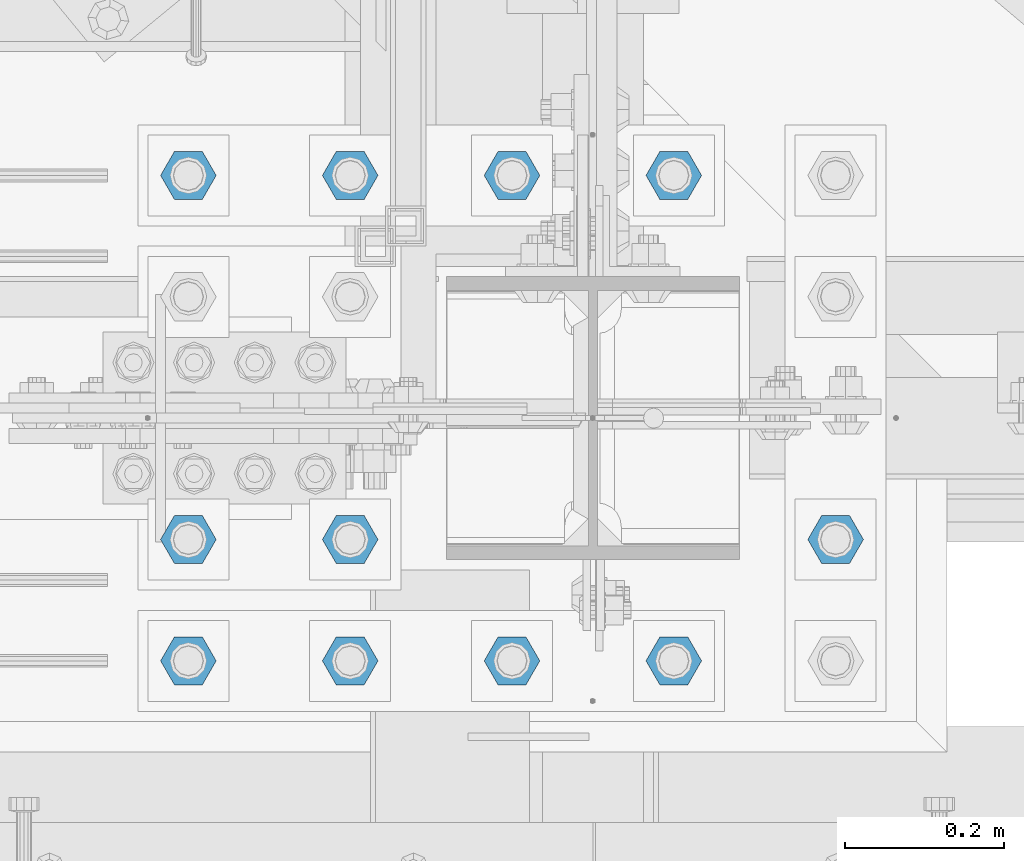
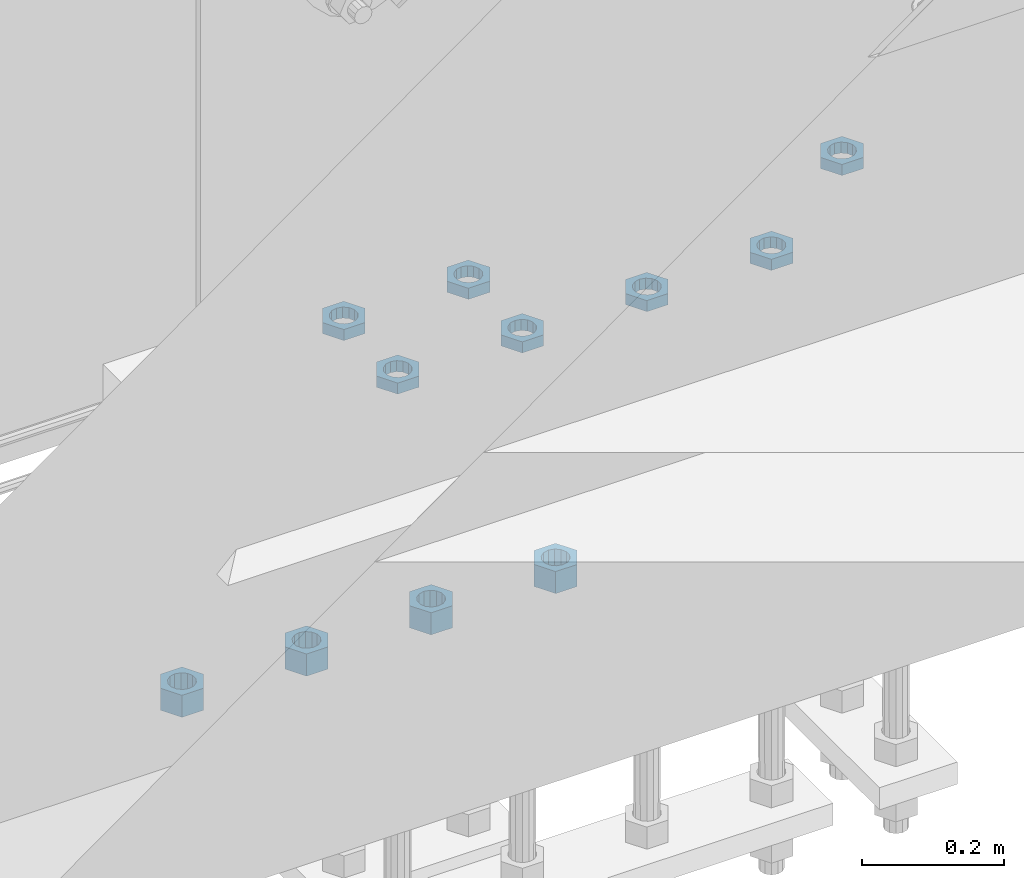
# One storey, part 2816 of 3843: 11 beams, 1 element without a shape of its own.
"""IFC2X3 building model written with IfcOpenShell, lengths in millimetres."""

from ifc_helpers import new_model, si_unit, frame, origin_with_axes, place, context, subcontext, project, spatial, faceted_brep, material, type_object, element, aggregate, save


model = new_model("IFC2X3")

# Units and contexts
model_context = context("Model", 3, precision=1e-05, world=origin_with_axes())
body_context = subcontext(model_context, "Body", "Model", "MODEL_VIEW")
ifc_project = project(units=[si_unit("LENGTHUNIT", "METRE", prefix="MILLI"), si_unit("AREAUNIT", "SQUARE_METRE"), si_unit("VOLUMEUNIT", "CUBIC_METRE"), si_unit("MASSUNIT", "GRAM", prefix="KILO"), si_unit("TIMEUNIT", "SECOND"), si_unit("PLANEANGLEUNIT", "RADIAN"), si_unit("SOLIDANGLEUNIT", "STERADIAN"), si_unit("THERMODYNAMICTEMPERATUREUNIT", "DEGREE_CELSIUS"), si_unit("LUMINOUSINTENSITYUNIT", "LUMEN")], contexts=[model_context])

# Site, building, storey
site_placement = place(None, origin_with_axes())
site = spatial("IfcSite", under=ifc_project, at=site_placement, CompositionType="ELEMENT")
building_placement = place(site_placement, origin_with_axes())
building = spatial("IfcBuilding", under=site, at=building_placement, Name="Undefined", CompositionType="ELEMENT")
storey_placement = place(building_placement, origin_with_axes())
storey = spatial("IfcBuildingStorey", under=building, at=storey_placement, Name="Undefined", CompositionType="ELEMENT", Elevation=0.0)

# Assembly, beams
assembly_placement = place(storey_placement, origin_with_axes())
assembly = element("IfcElementAssembly", 1, at=assembly_placement, inside=storey, Name="TEMPLATE", AssemblyPlace="NOTDEFINED", PredefinedType="RIGID_FRAME")
ifc_material = material(Name="STEEL/A572-50")
beam_type_1 = type_object("IfcBeamType", Name="1-1/2_HEAVY_HEX_NUT", PredefinedType="NOTDEFINED")
beam_1_placement = place(assembly_placement, frame((49098.2, 25920.7, 28841.7000015259), z_axis=(0.0, -1.0, 0.0), x_axis=(0.0, 0.0, -1.0)))
beam_1 = element("IfcBeam", 2, at=beam_1_placement, type_object=beam_type_1, material=ifc_material, Name="NUT", ObjectType="1-1/2_HEAVY_HEX_NUT", context=body_context, shape_type="Brep", body=[
    faceted_brep([(0.0, -34.9199981689453, 0.0), (0.0, -17.4599990844727, -30.25), (38.0999999999985, -17.4599990844727, -30.25), (38.0999999999985, -34.9199981689453, 0.0), (0.0, 17.4599990844727, -30.25), (38.0999999999985, 17.4599990844727, -30.25), (0.0, 34.9199981689453, 0.0), (38.0999999999985, 34.9199981689453, 0.0), (0.0, 17.4599990844727, 30.25), (38.0999999999985, 17.4599990844727, 30.25), (0.0, -17.4599990844727, 30.25), (38.0999999999985, -17.4599990844727, 30.25), (0.0, 0.0, 20.6399993896484), (0.0, 8.9553601105581, 18.5959968835959), (38.0999999999985, 8.9553601105581, 18.5959968835959), (38.0999999999985, 0.0, 20.6399993896484), (0.0, 16.1370013209525, 12.8688291298167), (38.0999999999985, 16.1370013209525, 12.8688291298167), (0.0, 20.1225115123816, 4.59283194104501), (38.0999999999985, 20.1225115123816, 4.59283194104501), (0.0, 20.1225115123816, -4.59283194104501), (38.0999999999985, 20.1225115123816, -4.59283194104501), (0.0, 16.1370013209525, -12.8688291298167), (38.0999999999985, 16.1370013209525, -12.8688291298167), (0.0, 8.9553601105581, -18.5959968835959), (38.0999999999985, 8.9553601105581, -18.5959968835959), (0.0, 0.0, -20.6399993896484), (38.0999999999985, 0.0, -20.6399993896484), (0.0, -8.9553601105581, -18.5959968835959), (38.0999999999985, -8.9553601105581, -18.5959968835959), (0.0, -16.1370013209525, -12.8688291298167), (38.0999999999985, -16.1370013209525, -12.8688291298167), (0.0, -20.1225115123816, -4.59283194104501), (38.0999999999985, -20.1225115123816, -4.59283194104501), (0.0, -20.1225115123816, 4.59283194104501), (38.0999999999985, -20.1225115123816, 4.59283194104501), (0.0, -16.1370013209525, 12.8688291298167), (38.0999999999985, -16.1370013209525, 12.8688291298167), (0.0, -8.9553601105581, 18.5959968835959), (38.0999999999985, -8.9553601105581, 18.5959968835959)], [[[0, 1, 2, 3]], [[1, 4, 5, 2]], [[4, 6, 7, 5]], [[6, 8, 9, 7]], [[8, 10, 11, 9]], [[10, 0, 3, 11]], [[12, 13, 14, 15]], [[13, 16, 17, 14]], [[16, 18, 19, 17]], [[18, 20, 21, 19]], [[20, 22, 23, 21]], [[22, 24, 25, 23]], [[24, 26, 27, 25]], [[26, 28, 29, 27]], [[28, 30, 31, 29]], [[30, 32, 33, 31]], [[32, 34, 35, 33]], [[34, 36, 37, 35]], [[36, 38, 39, 37]], [[38, 12, 15, 39]], [[5, 7, 9, 11, 3, 2], [17, 19, 21, 23, 25, 27, 29, 31, 33, 35, 37, 39, 15, 14]], [[10, 8, 6, 4, 1, 0], [38, 36, 34, 32, 30, 28, 26, 24, 22, 20, 18, 16, 13, 12]]]),
])
beam_2_placement = place(assembly_placement, frame((48895.0, 25920.7, 28841.7000015259), z_axis=(0.0, -1.0, 0.0), x_axis=(0.0, 0.0, -1.0)))
beam_2 = element("IfcBeam", 3, at=beam_2_placement, type_object=beam_type_1, material=ifc_material, Name="NUT", ObjectType="1-1/2_HEAVY_HEX_NUT", context=body_context, shape_type="Brep", body=[
    faceted_brep([(0.0, -34.9199981689453, 0.0), (0.0, -17.4599990844727, -30.25), (38.0999999999985, -17.4599990844727, -30.25), (38.0999999999985, -34.9199981689453, 0.0), (0.0, 17.4599990844727, -30.25), (38.0999999999985, 17.4599990844727, -30.25), (0.0, 34.9199981689453, 0.0), (38.0999999999985, 34.9199981689453, 0.0), (0.0, 17.4599990844727, 30.25), (38.0999999999985, 17.4599990844727, 30.25), (0.0, -17.4599990844727, 30.25), (38.0999999999985, -17.4599990844727, 30.25), (0.0, 0.0, 20.6399993896484), (0.0, 8.9553601105581, 18.5959968835959), (38.0999999999985, 8.9553601105581, 18.5959968835959), (38.0999999999985, 0.0, 20.6399993896484), (0.0, 16.1370013209525, 12.8688291298167), (38.0999999999985, 16.1370013209525, 12.8688291298167), (0.0, 20.1225115123816, 4.59283194104501), (38.0999999999985, 20.1225115123816, 4.59283194104501), (0.0, 20.1225115123816, -4.59283194104501), (38.0999999999985, 20.1225115123816, -4.59283194104501), (0.0, 16.1370013209525, -12.8688291298167), (38.0999999999985, 16.1370013209525, -12.8688291298167), (0.0, 8.9553601105581, -18.5959968835959), (38.0999999999985, 8.9553601105581, -18.5959968835959), (0.0, 0.0, -20.6399993896484), (38.0999999999985, 0.0, -20.6399993896484), (0.0, -8.9553601105581, -18.5959968835959), (38.0999999999985, -8.9553601105581, -18.5959968835959), (0.0, -16.1370013209525, -12.8688291298167), (38.0999999999985, -16.1370013209525, -12.8688291298167), (0.0, -20.1225115123816, -4.59283194104501), (38.0999999999985, -20.1225115123816, -4.59283194104501), (0.0, -20.1225115123816, 4.59283194104501), (38.0999999999985, -20.1225115123816, 4.59283194104501), (0.0, -16.1370013209525, 12.8688291298167), (38.0999999999985, -16.1370013209525, 12.8688291298167), (0.0, -8.9553601105581, 18.5959968835959), (38.0999999999985, -8.9553601105581, 18.5959968835959)], [[[0, 1, 2, 3]], [[1, 4, 5, 2]], [[4, 6, 7, 5]], [[6, 8, 9, 7]], [[8, 10, 11, 9]], [[10, 0, 3, 11]], [[12, 13, 14, 15]], [[13, 16, 17, 14]], [[16, 18, 19, 17]], [[18, 20, 21, 19]], [[20, 22, 23, 21]], [[22, 24, 25, 23]], [[24, 26, 27, 25]], [[26, 28, 29, 27]], [[28, 30, 31, 29]], [[30, 32, 33, 31]], [[32, 34, 35, 33]], [[34, 36, 37, 35]], [[36, 38, 39, 37]], [[38, 12, 15, 39]], [[5, 7, 9, 11, 3, 2], [17, 19, 21, 23, 25, 27, 29, 31, 33, 35, 37, 39, 15, 14]], [[10, 8, 6, 4, 1, 0], [38, 36, 34, 32, 30, 28, 26, 24, 22, 20, 18, 16, 13, 12]]]),
])
beam_3_placement = place(assembly_placement, frame((48691.8, 25920.7, 28841.7000015259), z_axis=(0.0, 1.0, 0.0), x_axis=(0.0, 0.0, -1.0)))
beam_3 = element("IfcBeam", 4, at=beam_3_placement, type_object=beam_type_1, material=ifc_material, Name="NUT", ObjectType="1-1/2_HEAVY_HEX_NUT", context=body_context, shape_type="Brep", body=[
    faceted_brep([(0.0, -34.9199981689453, 0.0), (0.0, -17.4599990844727, -30.25), (38.0999999999985, -17.4599990844727, -30.25), (38.0999999999985, -34.9199981689453, 0.0), (0.0, 17.4599990844727, -30.25), (38.0999999999985, 17.4599990844727, -30.25), (0.0, 34.9199981689453, 0.0), (38.0999999999985, 34.9199981689453, 0.0), (0.0, 17.4599990844727, 30.25), (38.0999999999985, 17.4599990844727, 30.25), (0.0, -17.4599990844727, 30.25), (38.0999999999985, -17.4599990844727, 30.25), (0.0, 0.0, 20.6399993896484), (0.0, 8.9553601105581, 18.5959968835959), (38.0999999999985, 8.9553601105581, 18.5959968835959), (38.0999999999985, 0.0, 20.6399993896484), (0.0, 16.1370013209525, 12.8688291298167), (38.0999999999985, 16.1370013209525, 12.8688291298167), (0.0, 20.1225115123816, 4.59283194104501), (38.0999999999985, 20.1225115123816, 4.59283194104501), (0.0, 20.1225115123816, -4.59283194104501), (38.0999999999985, 20.1225115123816, -4.59283194104501), (0.0, 16.1370013209525, -12.8688291298167), (38.0999999999985, 16.1370013209525, -12.8688291298167), (0.0, 8.9553601105581, -18.5959968835959), (38.0999999999985, 8.9553601105581, -18.5959968835959), (0.0, 0.0, -20.6399993896484), (38.0999999999985, 0.0, -20.6399993896484), (0.0, -8.9553601105581, -18.5959968835959), (38.0999999999985, -8.9553601105581, -18.5959968835959), (0.0, -16.1370013209525, -12.8688291298167), (38.0999999999985, -16.1370013209525, -12.8688291298167), (0.0, -20.1225115123816, -4.59283194104501), (38.0999999999985, -20.1225115123816, -4.59283194104501), (0.0, -20.1225115123816, 4.59283194104501), (38.0999999999985, -20.1225115123816, 4.59283194104501), (0.0, -16.1370013209525, 12.8688291298167), (38.0999999999985, -16.1370013209525, 12.8688291298167), (0.0, -8.9553601105581, 18.5959968835959), (38.0999999999985, -8.9553601105581, 18.5959968835959)], [[[0, 1, 2, 3]], [[1, 4, 5, 2]], [[4, 6, 7, 5]], [[6, 8, 9, 7]], [[8, 10, 11, 9]], [[10, 0, 3, 11]], [[12, 13, 14, 15]], [[13, 16, 17, 14]], [[16, 18, 19, 17]], [[18, 20, 21, 19]], [[20, 22, 23, 21]], [[22, 24, 25, 23]], [[24, 26, 27, 25]], [[26, 28, 29, 27]], [[28, 30, 31, 29]], [[30, 32, 33, 31]], [[32, 34, 35, 33]], [[34, 36, 37, 35]], [[36, 38, 39, 37]], [[38, 12, 15, 39]], [[5, 7, 9, 11, 3, 2], [17, 19, 21, 23, 25, 27, 29, 31, 33, 35, 37, 39, 15, 14]], [[10, 8, 6, 4, 1, 0], [38, 36, 34, 32, 30, 28, 26, 24, 22, 20, 18, 16, 13, 12]]]),
])
beam_4_placement = place(assembly_placement, frame((48488.6, 25920.7, 28841.7000015259), z_axis=(0.0, 1.0, 0.0), x_axis=(0.0, 0.0, -1.0)))
beam_4 = element("IfcBeam", 5, at=beam_4_placement, type_object=beam_type_1, material=ifc_material, Name="NUT", ObjectType="1-1/2_HEAVY_HEX_NUT", context=body_context, shape_type="Brep", body=[
    faceted_brep([(0.0, -34.9199981689453, 0.0), (0.0, -17.4599990844727, -30.25), (38.0999999999985, -17.4599990844727, -30.25), (38.0999999999985, -34.9199981689453, 0.0), (0.0, 17.4599990844727, -30.25), (38.0999999999985, 17.4599990844727, -30.25), (0.0, 34.9199981689453, 0.0), (38.0999999999985, 34.9199981689453, 0.0), (0.0, 17.4599990844727, 30.25), (38.0999999999985, 17.4599990844727, 30.25), (0.0, -17.4599990844727, 30.25), (38.0999999999985, -17.4599990844727, 30.25), (0.0, 0.0, 20.6399993896484), (0.0, 8.9553601105581, 18.5959968835959), (38.0999999999985, 8.9553601105581, 18.5959968835959), (38.0999999999985, 0.0, 20.6399993896484), (0.0, 16.1370013209525, 12.8688291298167), (38.0999999999985, 16.1370013209525, 12.8688291298167), (0.0, 20.1225115123816, 4.59283194104501), (38.0999999999985, 20.1225115123816, 4.59283194104501), (0.0, 20.1225115123816, -4.59283194104501), (38.0999999999985, 20.1225115123816, -4.59283194104501), (0.0, 16.1370013209525, -12.8688291298167), (38.0999999999985, 16.1370013209525, -12.8688291298167), (0.0, 8.9553601105581, -18.5959968835959), (38.0999999999985, 8.9553601105581, -18.5959968835959), (0.0, 0.0, -20.6399993896484), (38.0999999999985, 0.0, -20.6399993896484), (0.0, -8.9553601105581, -18.5959968835959), (38.0999999999985, -8.9553601105581, -18.5959968835959), (0.0, -16.1370013209525, -12.8688291298167), (38.0999999999985, -16.1370013209525, -12.8688291298167), (0.0, -20.1225115123816, -4.59283194104501), (38.0999999999985, -20.1225115123816, -4.59283194104501), (0.0, -20.1225115123816, 4.59283194104501), (38.0999999999985, -20.1225115123816, 4.59283194104501), (0.0, -16.1370013209525, 12.8688291298167), (38.0999999999985, -16.1370013209525, 12.8688291298167), (0.0, -8.9553601105581, 18.5959968835959), (38.0999999999985, -8.9553601105581, 18.5959968835959)], [[[0, 1, 2, 3]], [[1, 4, 5, 2]], [[4, 6, 7, 5]], [[6, 8, 9, 7]], [[8, 10, 11, 9]], [[10, 0, 3, 11]], [[12, 13, 14, 15]], [[13, 16, 17, 14]], [[16, 18, 19, 17]], [[18, 20, 21, 19]], [[20, 22, 23, 21]], [[22, 24, 25, 23]], [[24, 26, 27, 25]], [[26, 28, 29, 27]], [[28, 30, 31, 29]], [[30, 32, 33, 31]], [[32, 34, 35, 33]], [[34, 36, 37, 35]], [[36, 38, 39, 37]], [[38, 12, 15, 39]], [[5, 7, 9, 11, 3, 2], [17, 19, 21, 23, 25, 27, 29, 31, 33, 35, 37, 39, 15, 14]], [[10, 8, 6, 4, 1, 0], [38, 36, 34, 32, 30, 28, 26, 24, 22, 20, 18, 16, 13, 12]]]),
])
beam_type_2 = type_object("IfcBeamType", Name="1-1/2_HALF_NUT", PredefinedType="NOTDEFINED")
beam_5_placement = place(assembly_placement, frame((49098.2, 25311.1, 29749.75), z_axis=(0.0, -1.0, 0.0), x_axis=(0.0, 0.0, -1.0)))
beam_5 = element("IfcBeam", 6, at=beam_5_placement, type_object=beam_type_2, material=ifc_material, Name="NUT", ObjectType="1-1/2_HALF_NUT", context=body_context, shape_type="Brep", body=[
    faceted_brep([(0.0, -34.9199981689453, 0.0), (0.0, -17.4599990844727, -30.25), (19.0500000000029, -17.4599990844727, -30.25), (19.0500000000029, -34.9199981689453, 0.0), (0.0, 17.4599990844727, -30.25), (19.0500000000029, 17.4599990844727, -30.25), (0.0, 34.9199981689453, 0.0), (19.0500000000029, 34.9199981689453, 0.0), (0.0, 17.4599990844727, 30.25), (19.0500000000029, 17.4599990844727, 30.25), (0.0, -17.4599990844727, 30.25), (19.0500000000029, -17.4599990844727, 30.25), (0.0, 0.0, 20.6399993896484), (0.0, 8.9553601105581, 18.5959968835959), (19.0500000000029, 8.95536011056538, 18.5959968835959), (19.0500000000029, 0.0, 20.6399993896484), (0.0, 16.1370013209525, 12.8688291298167), (19.0500000000029, 16.1370013209489, 12.8688291298167), (0.0, 20.1225115123816, 4.59283194104501), (19.0500000000029, 20.1225115123852, 4.59283194104501), (0.0, 20.1225115123816, -4.59283194104501), (19.0500000000029, 20.1225115123852, -4.59283194104501), (0.0, 16.1370013209525, -12.8688291298167), (19.0500000000029, 16.1370013209489, -12.8688291298167), (0.0, 8.9553601105581, -18.5959968835959), (19.0500000000029, 8.95536011056538, -18.5959968835959), (0.0, 0.0, -20.6399993896484), (19.0500000000029, 0.0, -20.6399993896484), (0.0, -8.9553601105581, -18.5959968835959), (19.0500000000029, -8.95536011056538, -18.5959968835959), (0.0, -16.1370013209525, -12.8688291298167), (19.0500000000029, -16.1370013209489, -12.8688291298167), (0.0, -20.1225115123816, -4.59283194104501), (19.0500000000029, -20.1225115123852, -4.59283194104501), (0.0, -20.1225115123816, 4.59283194104501), (19.0500000000029, -20.1225115123852, 4.59283194104501), (0.0, -16.1370013209525, 12.8688291298167), (19.0500000000029, -16.1370013209489, 12.8688291298167), (0.0, -8.9553601105581, 18.5959968835959), (19.0500000000029, -8.95536011056538, 18.5959968835959)], [[[0, 1, 2, 3]], [[1, 4, 5, 2]], [[4, 6, 7, 5]], [[6, 8, 9, 7]], [[8, 10, 11, 9]], [[10, 0, 3, 11]], [[12, 13, 14, 15]], [[13, 16, 17, 14]], [[16, 18, 19, 17]], [[18, 20, 21, 19]], [[20, 22, 23, 21]], [[22, 24, 25, 23]], [[24, 26, 27, 25]], [[26, 28, 29, 27]], [[28, 30, 31, 29]], [[30, 32, 33, 31]], [[32, 34, 35, 33]], [[34, 36, 37, 35]], [[36, 38, 39, 37]], [[38, 12, 15, 39]], [[5, 7, 9, 11, 3, 2], [17, 19, 21, 23, 25, 27, 29, 31, 33, 35, 37, 39, 15, 14]], [[10, 8, 6, 4, 1, 0], [38, 36, 34, 32, 30, 28, 26, 24, 22, 20, 18, 16, 13, 12]]]),
])
beam_6_placement = place(assembly_placement, frame((48895.0, 25311.1, 29749.75), z_axis=(0.0, -1.0, 0.0), x_axis=(0.0, 0.0, -1.0)))
beam_6 = element("IfcBeam", 7, at=beam_6_placement, type_object=beam_type_2, material=ifc_material, Name="NUT", ObjectType="1-1/2_HALF_NUT", context=body_context, shape_type="Brep", body=[
    faceted_brep([(0.0, -34.9199981689453, 0.0), (0.0, -17.4599990844727, -30.25), (19.0500000000029, -17.4599990844727, -30.25), (19.0500000000029, -34.9199981689453, 0.0), (0.0, 17.4599990844727, -30.25), (19.0500000000029, 17.4599990844727, -30.25), (0.0, 34.9199981689453, 0.0), (19.0500000000029, 34.9199981689453, 0.0), (0.0, 17.4599990844727, 30.25), (19.0500000000029, 17.4599990844727, 30.25), (0.0, -17.4599990844727, 30.25), (19.0500000000029, -17.4599990844727, 30.25), (0.0, 0.0, 20.6399993896484), (0.0, 8.9553601105581, 18.5959968835959), (19.0500000000029, 8.95536011056538, 18.5959968835959), (19.0500000000029, 0.0, 20.6399993896484), (0.0, 16.1370013209525, 12.8688291298167), (19.0500000000029, 16.1370013209489, 12.8688291298167), (0.0, 20.1225115123816, 4.59283194104501), (19.0500000000029, 20.1225115123852, 4.59283194104501), (0.0, 20.1225115123816, -4.59283194104501), (19.0500000000029, 20.1225115123852, -4.59283194104501), (0.0, 16.1370013209525, -12.8688291298167), (19.0500000000029, 16.1370013209489, -12.8688291298167), (0.0, 8.9553601105581, -18.5959968835959), (19.0500000000029, 8.95536011056538, -18.5959968835959), (0.0, 0.0, -20.6399993896484), (19.0500000000029, 0.0, -20.6399993896484), (0.0, -8.9553601105581, -18.5959968835959), (19.0500000000029, -8.95536011056538, -18.5959968835959), (0.0, -16.1370013209525, -12.8688291298167), (19.0500000000029, -16.1370013209489, -12.8688291298167), (0.0, -20.1225115123816, -4.59283194104501), (19.0500000000029, -20.1225115123852, -4.59283194104501), (0.0, -20.1225115123816, 4.59283194104501), (19.0500000000029, -20.1225115123852, 4.59283194104501), (0.0, -16.1370013209525, 12.8688291298167), (19.0500000000029, -16.1370013209489, 12.8688291298167), (0.0, -8.9553601105581, 18.5959968835959), (19.0500000000029, -8.95536011056538, 18.5959968835959)], [[[0, 1, 2, 3]], [[1, 4, 5, 2]], [[4, 6, 7, 5]], [[6, 8, 9, 7]], [[8, 10, 11, 9]], [[10, 0, 3, 11]], [[12, 13, 14, 15]], [[13, 16, 17, 14]], [[16, 18, 19, 17]], [[18, 20, 21, 19]], [[20, 22, 23, 21]], [[22, 24, 25, 23]], [[24, 26, 27, 25]], [[26, 28, 29, 27]], [[28, 30, 31, 29]], [[30, 32, 33, 31]], [[32, 34, 35, 33]], [[34, 36, 37, 35]], [[36, 38, 39, 37]], [[38, 12, 15, 39]], [[5, 7, 9, 11, 3, 2], [17, 19, 21, 23, 25, 27, 29, 31, 33, 35, 37, 39, 15, 14]], [[10, 8, 6, 4, 1, 0], [38, 36, 34, 32, 30, 28, 26, 24, 22, 20, 18, 16, 13, 12]]]),
])
beam_7_placement = place(assembly_placement, frame((48691.8, 25311.1, 29749.75), z_axis=(0.0, 1.0, 0.0), x_axis=(0.0, 0.0, -1.0)))
beam_7 = element("IfcBeam", 8, at=beam_7_placement, type_object=beam_type_2, material=ifc_material, Name="NUT", ObjectType="1-1/2_HALF_NUT", context=body_context, shape_type="Brep", body=[
    faceted_brep([(0.0, -34.9199981689453, 0.0), (0.0, -17.4599990844727, -30.25), (19.0500000000029, -17.4599990844727, -30.25), (19.0500000000029, -34.9199981689453, 0.0), (0.0, 17.4599990844727, -30.25), (19.0500000000029, 17.4599990844727, -30.25), (0.0, 34.9199981689453, 0.0), (19.0500000000029, 34.9199981689453, 0.0), (0.0, 17.4599990844727, 30.25), (19.0500000000029, 17.4599990844727, 30.25), (0.0, -17.4599990844727, 30.25), (19.0500000000029, -17.4599990844727, 30.25), (0.0, 0.0, 20.6399993896484), (0.0, 8.9553601105581, 18.5959968835959), (19.0500000000029, 8.95536011056538, 18.5959968835959), (19.0500000000029, 0.0, 20.6399993896484), (0.0, 16.1370013209525, 12.8688291298167), (19.0500000000029, 16.1370013209489, 12.8688291298167), (0.0, 20.1225115123816, 4.59283194104501), (19.0500000000029, 20.1225115123852, 4.59283194104501), (0.0, 20.1225115123816, -4.59283194104501), (19.0500000000029, 20.1225115123852, -4.59283194104501), (0.0, 16.1370013209525, -12.8688291298167), (19.0500000000029, 16.1370013209489, -12.8688291298167), (0.0, 8.9553601105581, -18.5959968835959), (19.0500000000029, 8.95536011056538, -18.5959968835959), (0.0, 0.0, -20.6399993896484), (19.0500000000029, 0.0, -20.6399993896484), (0.0, -8.9553601105581, -18.5959968835959), (19.0500000000029, -8.95536011056538, -18.5959968835959), (0.0, -16.1370013209525, -12.8688291298167), (19.0500000000029, -16.1370013209489, -12.8688291298167), (0.0, -20.1225115123816, -4.59283194104501), (19.0500000000029, -20.1225115123852, -4.59283194104501), (0.0, -20.1225115123816, 4.59283194104501), (19.0500000000029, -20.1225115123852, 4.59283194104501), (0.0, -16.1370013209525, 12.8688291298167), (19.0500000000029, -16.1370013209489, 12.8688291298167), (0.0, -8.9553601105581, 18.5959968835959), (19.0500000000029, -8.95536011056538, 18.5959968835959)], [[[0, 1, 2, 3]], [[1, 4, 5, 2]], [[4, 6, 7, 5]], [[6, 8, 9, 7]], [[8, 10, 11, 9]], [[10, 0, 3, 11]], [[12, 13, 14, 15]], [[13, 16, 17, 14]], [[16, 18, 19, 17]], [[18, 20, 21, 19]], [[20, 22, 23, 21]], [[22, 24, 25, 23]], [[24, 26, 27, 25]], [[26, 28, 29, 27]], [[28, 30, 31, 29]], [[30, 32, 33, 31]], [[32, 34, 35, 33]], [[34, 36, 37, 35]], [[36, 38, 39, 37]], [[38, 12, 15, 39]], [[5, 7, 9, 11, 3, 2], [17, 19, 21, 23, 25, 27, 29, 31, 33, 35, 37, 39, 15, 14]], [[10, 8, 6, 4, 1, 0], [38, 36, 34, 32, 30, 28, 26, 24, 22, 20, 18, 16, 13, 12]]]),
])
beam_8_placement = place(assembly_placement, frame((48488.6, 25311.1, 29749.75), z_axis=(0.0, 1.0, 0.0), x_axis=(0.0, 0.0, -1.0)))
beam_8 = element("IfcBeam", 9, at=beam_8_placement, type_object=beam_type_2, material=ifc_material, Name="NUT", ObjectType="1-1/2_HALF_NUT", context=body_context, shape_type="Brep", body=[
    faceted_brep([(0.0, -34.9199981689453, 0.0), (0.0, -17.4599990844727, -30.25), (19.0500000000029, -17.4599990844727, -30.25), (19.0500000000029, -34.9199981689453, 0.0), (0.0, 17.4599990844727, -30.25), (19.0500000000029, 17.4599990844727, -30.25), (0.0, 34.9199981689453, 0.0), (19.0500000000029, 34.9199981689453, 0.0), (0.0, 17.4599990844727, 30.25), (19.0500000000029, 17.4599990844727, 30.25), (0.0, -17.4599990844727, 30.25), (19.0500000000029, -17.4599990844727, 30.25), (0.0, 0.0, 20.6399993896484), (0.0, 8.9553601105581, 18.5959968835959), (19.0500000000029, 8.95536011056538, 18.5959968835959), (19.0500000000029, 0.0, 20.6399993896484), (0.0, 16.1370013209525, 12.8688291298167), (19.0500000000029, 16.1370013209489, 12.8688291298167), (0.0, 20.1225115123816, 4.59283194104501), (19.0500000000029, 20.1225115123852, 4.59283194104501), (0.0, 20.1225115123816, -4.59283194104501), (19.0500000000029, 20.1225115123852, -4.59283194104501), (0.0, 16.1370013209525, -12.8688291298167), (19.0500000000029, 16.1370013209489, -12.8688291298167), (0.0, 8.9553601105581, -18.5959968835959), (19.0500000000029, 8.95536011056538, -18.5959968835959), (0.0, 0.0, -20.6399993896484), (19.0500000000029, 0.0, -20.6399993896484), (0.0, -8.9553601105581, -18.5959968835959), (19.0500000000029, -8.95536011056538, -18.5959968835959), (0.0, -16.1370013209525, -12.8688291298167), (19.0500000000029, -16.1370013209489, -12.8688291298167), (0.0, -20.1225115123816, -4.59283194104501), (19.0500000000029, -20.1225115123852, -4.59283194104501), (0.0, -20.1225115123816, 4.59283194104501), (19.0500000000029, -20.1225115123852, 4.59283194104501), (0.0, -16.1370013209525, 12.8688291298167), (19.0500000000029, -16.1370013209489, 12.8688291298167), (0.0, -8.9553601105581, 18.5959968835959), (19.0500000000029, -8.95536011056538, 18.5959968835959)], [[[0, 1, 2, 3]], [[1, 4, 5, 2]], [[4, 6, 7, 5]], [[6, 8, 9, 7]], [[8, 10, 11, 9]], [[10, 0, 3, 11]], [[12, 13, 14, 15]], [[13, 16, 17, 14]], [[16, 18, 19, 17]], [[18, 20, 21, 19]], [[20, 22, 23, 21]], [[22, 24, 25, 23]], [[24, 26, 27, 25]], [[26, 28, 29, 27]], [[28, 30, 31, 29]], [[30, 32, 33, 31]], [[32, 34, 35, 33]], [[34, 36, 37, 35]], [[36, 38, 39, 37]], [[38, 12, 15, 39]], [[5, 7, 9, 11, 3, 2], [17, 19, 21, 23, 25, 27, 29, 31, 33, 35, 37, 39, 15, 14]], [[10, 8, 6, 4, 1, 0], [38, 36, 34, 32, 30, 28, 26, 24, 22, 20, 18, 16, 13, 12]]]),
])
beam_9_placement = place(assembly_placement, frame((49301.4, 25463.5, 29749.75), z_axis=(0.0, -1.0, 0.0), x_axis=(0.0, 0.0, -1.0)))
beam_9 = element("IfcBeam", 10, at=beam_9_placement, type_object=beam_type_2, material=ifc_material, Name="NUT", ObjectType="1-1/2_HALF_NUT", context=body_context, shape_type="Brep", body=[
    faceted_brep([(0.0, -34.9199981689453, 0.0), (0.0, -17.4599990844727, -30.25), (19.0500000000029, -17.4599990844727, -30.25), (19.0500000000029, -34.9199981689453, 0.0), (0.0, 17.4599990844727, -30.25), (19.0500000000029, 17.4599990844727, -30.25), (0.0, 34.9199981689453, 0.0), (19.0500000000029, 34.9199981689453, 0.0), (0.0, 17.4599990844727, 30.25), (19.0500000000029, 17.4599990844727, 30.25), (0.0, -17.4599990844727, 30.25), (19.0500000000029, -17.4599990844727, 30.25), (0.0, 0.0, 20.6399993896484), (0.0, 8.9553601105581, 18.5959968835959), (19.0500000000029, 8.95536011056538, 18.5959968835959), (19.0500000000029, 0.0, 20.6399993896484), (0.0, 16.1370013209525, 12.8688291298167), (19.0500000000029, 16.1370013209489, 12.8688291298167), (0.0, 20.1225115123816, 4.59283194104501), (19.0500000000029, 20.1225115123852, 4.59283194104501), (0.0, 20.1225115123816, -4.59283194104501), (19.0500000000029, 20.1225115123852, -4.59283194104501), (0.0, 16.1370013209525, -12.8688291298167), (19.0500000000029, 16.1370013209489, -12.8688291298167), (0.0, 8.9553601105581, -18.5959968835959), (19.0500000000029, 8.95536011056538, -18.5959968835959), (0.0, 0.0, -20.6399993896484), (19.0500000000029, 0.0, -20.6399993896484), (0.0, -8.9553601105581, -18.5959968835959), (19.0500000000029, -8.95536011056538, -18.5959968835959), (0.0, -16.1370013209525, -12.8688291298167), (19.0500000000029, -16.1370013209489, -12.8688291298167), (0.0, -20.1225115123816, -4.59283194104501), (19.0500000000029, -20.1225115123852, -4.59283194104501), (0.0, -20.1225115123816, 4.59283194104501), (19.0500000000029, -20.1225115123852, 4.59283194104501), (0.0, -16.1370013209525, 12.8688291298167), (19.0500000000029, -16.1370013209489, 12.8688291298167), (0.0, -8.9553601105581, 18.5959968835959), (19.0500000000029, -8.95536011056538, 18.5959968835959)], [[[0, 1, 2, 3]], [[1, 4, 5, 2]], [[4, 6, 7, 5]], [[6, 8, 9, 7]], [[8, 10, 11, 9]], [[10, 0, 3, 11]], [[12, 13, 14, 15]], [[13, 16, 17, 14]], [[16, 18, 19, 17]], [[18, 20, 21, 19]], [[20, 22, 23, 21]], [[22, 24, 25, 23]], [[24, 26, 27, 25]], [[26, 28, 29, 27]], [[28, 30, 31, 29]], [[30, 32, 33, 31]], [[32, 34, 35, 33]], [[34, 36, 37, 35]], [[36, 38, 39, 37]], [[38, 12, 15, 39]], [[5, 7, 9, 11, 3, 2], [17, 19, 21, 23, 25, 27, 29, 31, 33, 35, 37, 39, 15, 14]], [[10, 8, 6, 4, 1, 0], [38, 36, 34, 32, 30, 28, 26, 24, 22, 20, 18, 16, 13, 12]]]),
])
beam_10_placement = place(assembly_placement, frame((48691.8, 25463.5, 29749.75), z_axis=(0.0, 1.0, 0.0), x_axis=(0.0, 0.0, -1.0)))
beam_10 = element("IfcBeam", 11, at=beam_10_placement, type_object=beam_type_2, material=ifc_material, Name="NUT", ObjectType="1-1/2_HALF_NUT", context=body_context, shape_type="Brep", body=[
    faceted_brep([(0.0, -34.9199981689453, 0.0), (0.0, -17.4599990844727, -30.25), (19.0500000000029, -17.4599990844727, -30.25), (19.0500000000029, -34.9199981689453, 0.0), (0.0, 17.4599990844727, -30.25), (19.0500000000029, 17.4599990844727, -30.25), (0.0, 34.9199981689453, 0.0), (19.0500000000029, 34.9199981689453, 0.0), (0.0, 17.4599990844727, 30.25), (19.0500000000029, 17.4599990844727, 30.25), (0.0, -17.4599990844727, 30.25), (19.0500000000029, -17.4599990844727, 30.25), (0.0, 0.0, 20.6399993896484), (0.0, 8.9553601105581, 18.5959968835959), (19.0500000000029, 8.95536011056538, 18.5959968835959), (19.0500000000029, 0.0, 20.6399993896484), (0.0, 16.1370013209525, 12.8688291298167), (19.0500000000029, 16.1370013209489, 12.8688291298167), (0.0, 20.1225115123816, 4.59283194104501), (19.0500000000029, 20.1225115123852, 4.59283194104501), (0.0, 20.1225115123816, -4.59283194104501), (19.0500000000029, 20.1225115123852, -4.59283194104501), (0.0, 16.1370013209525, -12.8688291298167), (19.0500000000029, 16.1370013209489, -12.8688291298167), (0.0, 8.9553601105581, -18.5959968835959), (19.0500000000029, 8.95536011056538, -18.5959968835959), (0.0, 0.0, -20.6399993896484), (19.0500000000029, 0.0, -20.6399993896484), (0.0, -8.9553601105581, -18.5959968835959), (19.0500000000029, -8.95536011056538, -18.5959968835959), (0.0, -16.1370013209525, -12.8688291298167), (19.0500000000029, -16.1370013209489, -12.8688291298167), (0.0, -20.1225115123816, -4.59283194104501), (19.0500000000029, -20.1225115123852, -4.59283194104501), (0.0, -20.1225115123816, 4.59283194104501), (19.0500000000029, -20.1225115123852, 4.59283194104501), (0.0, -16.1370013209525, 12.8688291298167), (19.0500000000029, -16.1370013209489, 12.8688291298167), (0.0, -8.9553601105581, 18.5959968835959), (19.0500000000029, -8.95536011056538, 18.5959968835959)], [[[0, 1, 2, 3]], [[1, 4, 5, 2]], [[4, 6, 7, 5]], [[6, 8, 9, 7]], [[8, 10, 11, 9]], [[10, 0, 3, 11]], [[12, 13, 14, 15]], [[13, 16, 17, 14]], [[16, 18, 19, 17]], [[18, 20, 21, 19]], [[20, 22, 23, 21]], [[22, 24, 25, 23]], [[24, 26, 27, 25]], [[26, 28, 29, 27]], [[28, 30, 31, 29]], [[30, 32, 33, 31]], [[32, 34, 35, 33]], [[34, 36, 37, 35]], [[36, 38, 39, 37]], [[38, 12, 15, 39]], [[5, 7, 9, 11, 3, 2], [17, 19, 21, 23, 25, 27, 29, 31, 33, 35, 37, 39, 15, 14]], [[10, 8, 6, 4, 1, 0], [38, 36, 34, 32, 30, 28, 26, 24, 22, 20, 18, 16, 13, 12]]]),
])
beam_11_placement = place(assembly_placement, frame((48488.6, 25463.5, 29749.75), z_axis=(0.0, 1.0, 0.0), x_axis=(0.0, 0.0, -1.0)))
beam_11 = element("IfcBeam", 12, at=beam_11_placement, type_object=beam_type_2, material=ifc_material, Name="NUT", ObjectType="1-1/2_HALF_NUT", context=body_context, shape_type="Brep", body=[
    faceted_brep([(0.0, -34.9199981689453, 0.0), (0.0, -17.4599990844727, -30.25), (19.0500000000029, -17.4599990844727, -30.25), (19.0500000000029, -34.9199981689453, 0.0), (0.0, 17.4599990844727, -30.25), (19.0500000000029, 17.4599990844727, -30.25), (0.0, 34.9199981689453, 0.0), (19.0500000000029, 34.9199981689453, 0.0), (0.0, 17.4599990844727, 30.25), (19.0500000000029, 17.4599990844727, 30.25), (0.0, -17.4599990844727, 30.25), (19.0500000000029, -17.4599990844727, 30.25), (0.0, 0.0, 20.6399993896484), (0.0, 8.9553601105581, 18.5959968835959), (19.0500000000029, 8.95536011056538, 18.5959968835959), (19.0500000000029, 0.0, 20.6399993896484), (0.0, 16.1370013209525, 12.8688291298167), (19.0500000000029, 16.1370013209489, 12.8688291298167), (0.0, 20.1225115123816, 4.59283194104501), (19.0500000000029, 20.1225115123852, 4.59283194104501), (0.0, 20.1225115123816, -4.59283194104501), (19.0500000000029, 20.1225115123852, -4.59283194104501), (0.0, 16.1370013209525, -12.8688291298167), (19.0500000000029, 16.1370013209489, -12.8688291298167), (0.0, 8.9553601105581, -18.5959968835959), (19.0500000000029, 8.95536011056538, -18.5959968835959), (0.0, 0.0, -20.6399993896484), (19.0500000000029, 0.0, -20.6399993896484), (0.0, -8.9553601105581, -18.5959968835959), (19.0500000000029, -8.95536011056538, -18.5959968835959), (0.0, -16.1370013209525, -12.8688291298167), (19.0500000000029, -16.1370013209489, -12.8688291298167), (0.0, -20.1225115123816, -4.59283194104501), (19.0500000000029, -20.1225115123852, -4.59283194104501), (0.0, -20.1225115123816, 4.59283194104501), (19.0500000000029, -20.1225115123852, 4.59283194104501), (0.0, -16.1370013209525, 12.8688291298167), (19.0500000000029, -16.1370013209489, 12.8688291298167), (0.0, -8.9553601105581, 18.5959968835959), (19.0500000000029, -8.95536011056538, 18.5959968835959)], [[[0, 1, 2, 3]], [[1, 4, 5, 2]], [[4, 6, 7, 5]], [[6, 8, 9, 7]], [[8, 10, 11, 9]], [[10, 0, 3, 11]], [[12, 13, 14, 15]], [[13, 16, 17, 14]], [[16, 18, 19, 17]], [[18, 20, 21, 19]], [[20, 22, 23, 21]], [[22, 24, 25, 23]], [[24, 26, 27, 25]], [[26, 28, 29, 27]], [[28, 30, 31, 29]], [[30, 32, 33, 31]], [[32, 34, 35, 33]], [[34, 36, 37, 35]], [[36, 38, 39, 37]], [[38, 12, 15, 39]], [[5, 7, 9, 11, 3, 2], [17, 19, 21, 23, 25, 27, 29, 31, 33, 35, 37, 39, 15, 14]], [[10, 8, 6, 4, 1, 0], [38, 36, 34, 32, 30, 28, 26, 24, 22, 20, 18, 16, 13, 12]]]),
])
aggregate(assembly, [beam_1, beam_2, beam_3, beam_4, beam_5, beam_6, beam_7, beam_8, beam_9, beam_10, beam_11])

save(model, "model.ifc")
